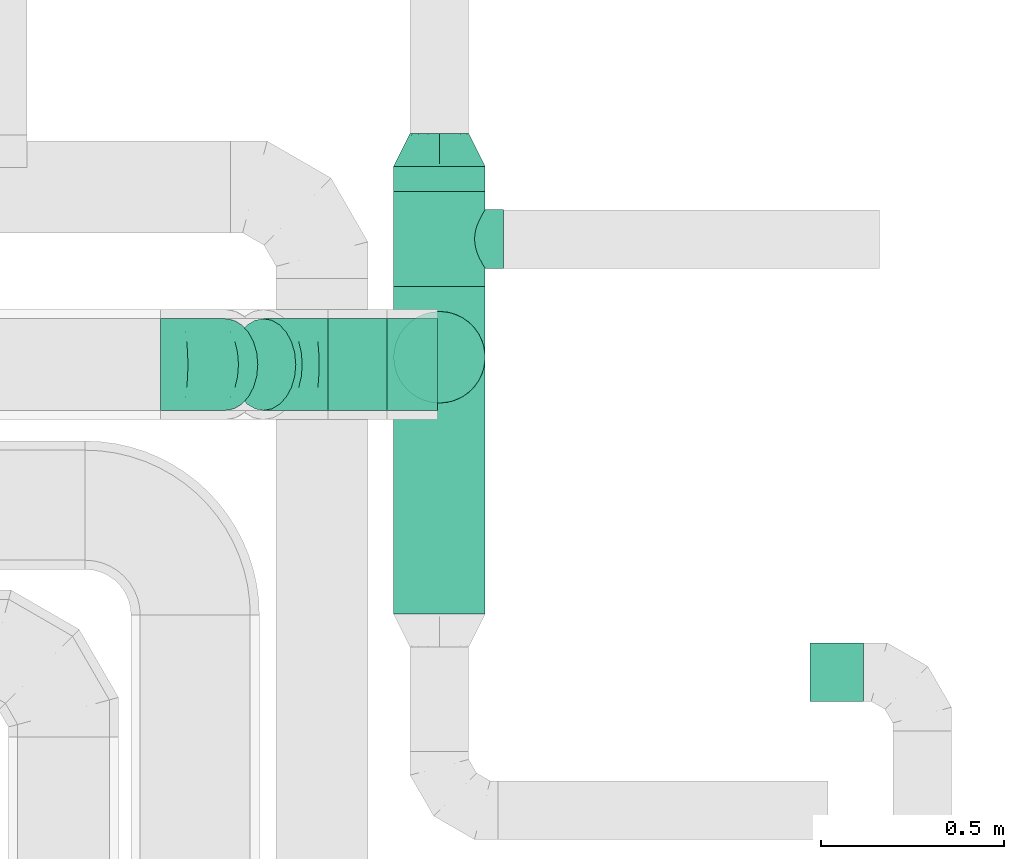
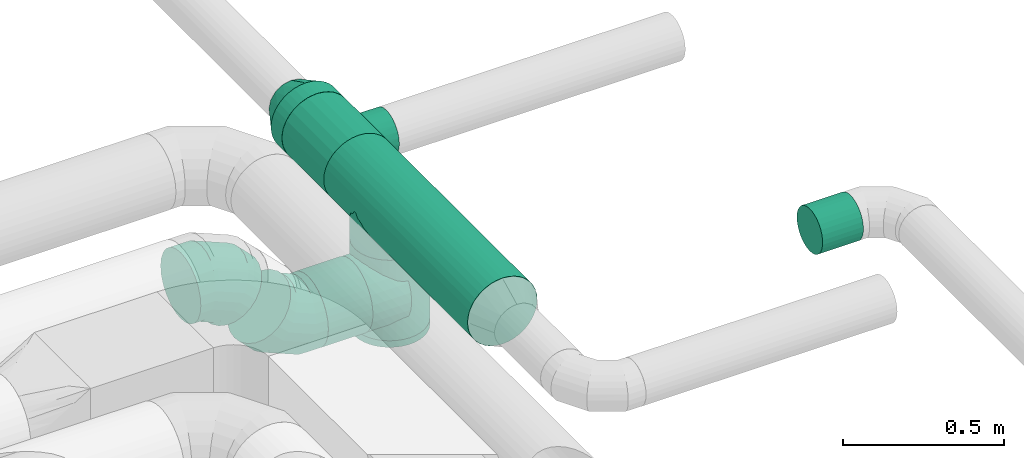
# One storey, part 74 of 92: 7 flow fittings, 5 flow segments.
"""IFC2X3 building model written with IfcOpenShell, lengths in millimetres."""

from ifc_helpers import new_model, entity, si_unit, converted_unit, derived_unit, direction, frame, origin, origin_2d_with_axis, place, context, subcontext, project, spatial, circle, extrude, faceted_brep, source, transform, mapped, material, type_object, type_shapes, element, save


model = new_model("IFC2X3")

# Units and contexts
model_context = context("Model", 3, precision=0.01, world=origin(), true_north=direction((6.12303176911189e-17, 1.0)))
body_context = subcontext(model_context, "Body", "Model", "MODEL_VIEW")
ifc_project = project(units=[si_unit("LENGTHUNIT", "METRE", prefix="MILLI"), si_unit("AREAUNIT", "SQUARE_METRE"), si_unit("VOLUMEUNIT", "CUBIC_METRE"), converted_unit("PLANEANGLEUNIT", "DEGREE", entity("IfcRatioMeasure", 0.0174532925199433), si_unit("PLANEANGLEUNIT", "RADIAN"), dimensions=[0, 0, 0, 0, 0, 0, 0]), si_unit("MASSUNIT", "GRAM", prefix="KILO"), derived_unit("MASSDENSITYUNIT", [(si_unit("MASSUNIT", "GRAM", prefix="KILO"), 1), (si_unit("LENGTHUNIT", "METRE"), -3)]), derived_unit("MOMENTOFINERTIAUNIT", [(si_unit("LENGTHUNIT", "METRE"), 4)]), si_unit("TIMEUNIT", "SECOND"), si_unit("FREQUENCYUNIT", "HERTZ"), si_unit("THERMODYNAMICTEMPERATUREUNIT", "DEGREE_CELSIUS"), derived_unit("THERMALTRANSMITTANCEUNIT", [(si_unit("MASSUNIT", "GRAM", prefix="KILO"), 1), (si_unit("THERMODYNAMICTEMPERATUREUNIT", "KELVIN"), -1), (si_unit("TIMEUNIT", "SECOND"), -3)]), derived_unit("VOLUMETRICFLOWRATEUNIT", [(si_unit("LENGTHUNIT", "METRE"), 3), (si_unit("TIMEUNIT", "SECOND"), -1)]), derived_unit("MASSFLOWRATEUNIT", [(si_unit("MASSUNIT", "GRAM", prefix="KILO"), 1), (si_unit("TIMEUNIT", "SECOND"), -1)]), derived_unit("ROTATIONALFREQUENCYUNIT", [(si_unit("TIMEUNIT", "SECOND"), -1)]), si_unit("ELECTRICCURRENTUNIT", "AMPERE"), si_unit("ELECTRICVOLTAGEUNIT", "VOLT"), si_unit("POWERUNIT", "WATT"), si_unit("FORCEUNIT", "NEWTON", prefix="KILO"), si_unit("ILLUMINANCEUNIT", "LUX"), si_unit("LUMINOUSFLUXUNIT", "LUMEN"), si_unit("LUMINOUSINTENSITYUNIT", "CANDELA"), derived_unit("USERDEFINED", [(si_unit("MASSUNIT", "GRAM", prefix="KILO"), -1), (si_unit("LENGTHUNIT", "METRE"), -2), (si_unit("TIMEUNIT", "SECOND"), 3), (si_unit("LUMINOUSFLUXUNIT", "LUMEN"), 1)]), derived_unit("LINEARVELOCITYUNIT", [(si_unit("LENGTHUNIT", "METRE"), 1), (si_unit("TIMEUNIT", "SECOND"), -1)]), si_unit("PRESSUREUNIT", "PASCAL"), derived_unit("USERDEFINED", [(si_unit("LENGTHUNIT", "METRE"), -2), (si_unit("MASSUNIT", "GRAM", prefix="KILO"), 1), (si_unit("TIMEUNIT", "SECOND"), -2)]), derived_unit("LINEARFORCEUNIT", [(si_unit("MASSUNIT", "GRAM", prefix="KILO"), 1), (si_unit("LENGTHUNIT", "METRE"), 1), (si_unit("TIMEUNIT", "SECOND"), -2), (si_unit("LENGTHUNIT", "METRE"), -1)]), derived_unit("PLANARFORCEUNIT", [(si_unit("MASSUNIT", "GRAM", prefix="KILO"), 1), (si_unit("LENGTHUNIT", "METRE"), 1), (si_unit("TIMEUNIT", "SECOND"), -2), (si_unit("LENGTHUNIT", "METRE"), -2)])], contexts=[model_context])

# Site, building, storey
site_placement = place(None, origin())
site = spatial("IfcSite", under=ifc_project, at=site_placement, CompositionType="ELEMENT")
building_placement = place(site_placement, origin())
building = spatial("IfcBuilding", under=site, at=building_placement, CompositionType="ELEMENT")
storey_placement = place(building_placement, frame((0.0, 0.0, 4200.0)))
storey = spatial("IfcBuildingStorey", under=building, at=storey_placement, CompositionType="ELEMENT", Elevation=4200.0)

# Flow segments
duct_segment_type = type_object("IfcDuctSegmentType", PredefinedType="NOTDEFINED")
flow_segment_1_placement = place(storey_placement, frame((63120.09, 14801.78, 3268.4)))
element("IfcFlowSegment", 1, at=flow_segment_1_placement, inside=storey, type_object=duct_segment_type, context=body_context, shape_type="SweptSolid", body=[
    extrude(circle(Radius=80.0, at=origin_2d_with_axis()), frame((0.0, 81.6, 81.6), z_axis=(1.0, 0.0, 0.0), x_axis=(0.0, 1.0, 0.0)), (0.0, 0.0, 1.0), 146.331439886492),
])
flow_segment_2_placement = place(storey_placement, frame((61806.89, 15595.41, 2873.4)))
element("IfcFlowSegment", 2, at=flow_segment_2_placement, inside=storey, type_object=duct_segment_type, context=body_context, shape_type="SweptSolid", body=[
    extrude(circle(Radius=125.0, at=origin_2d_with_axis()), frame((0.0, 126.6, 126.6), z_axis=(1.0, 0.0, 0.0), x_axis=(0.0, 1.0, 0.0)), (0.0, 0.0, 1.0), 159.717263995072),
])
flow_segment_3_placement = place(storey_placement, frame((61983.4, 15615.38, 2850.0)))
element("IfcFlowSegment", 3, at=flow_segment_3_placement, inside=storey, type_object=duct_segment_type, context=body_context, shape_type="SweptSolid", body=[
    extrude(circle(Radius=125.0, at=origin_2d_with_axis()), frame((126.6, 126.6, 0.0), z_axis=(0.0, 0.0, 1.0), x_axis=(0.0, -1.0, 0.0)), (0.0, 0.0, 1.0), 305.000000000008),
])
flow_segment_4_placement = place(storey_placement, frame((61983.4, 16194.33, 3173.4)))
element("IfcFlowSegment", 4, at=flow_segment_4_placement, inside=storey, type_object=duct_segment_type, context=body_context, shape_type="SweptSolid", body=[
    extrude(circle(Radius=125.0, at=origin_2d_with_axis()), frame((126.6, 0.0, 126.6), z_axis=(0.0, 1.0, 0.0), x_axis=(1.0, 0.0, 0.0)), (0.0, 0.0, 1.0), 67.6437884777552),
])
flow_segment_5_placement = place(storey_placement, frame((61983.4, 15041.98, 3173.4)))
element("IfcFlowSegment", 5, at=flow_segment_5_placement, inside=storey, type_object=duct_segment_type, context=body_context, shape_type="SweptSolid", body=[
    extrude(circle(Radius=125.0, at=origin_2d_with_axis()), frame((126.6, 0.0, 126.6), z_axis=(0.0, 1.0, 0.0), x_axis=(1.0, 0.0, 0.0)), (0.0, 0.0, 1.0), 892.356211522237),
])

# Flow fittings
ifc_material = material()
duct_fitting_type_1 = type_object("IfcDuctFittingType", PredefinedType="NOTDEFINED", material=ifc_material)
shared_shape_1 = source(origin(), body_context, "Body", "SweptSolid", [
    extrude(circle(Radius=124.999999999999, at=origin_2d_with_axis()), frame((0.0, 0.0, 0.0), z_axis=(1.0, 0.0, 0.0), x_axis=(0.0, 1.0, 0.0)), (0.0, 0.0, 1.0), 25.0000000000018),
])
type_shapes(duct_fitting_type_1, [shared_shape_1])
flow_fitting_1_placement = place(storey_placement, frame((62110.0, 15741.98, 2850.0), z_axis=(-1.0, 0.0, 0.0), x_axis=(0.0, 0.0, -1.0)))
element("IfcFlowFitting", 6, at=flow_fitting_1_placement, inside=storey, type_object=duct_fitting_type_1, material=ifc_material, context=body_context, shape_type="MappedRepresentation", body=[
    mapped(shared_shape_1, transform((0.0, 0.0, 0.0), scale=1.0)),
])
duct_fitting_type_2 = type_object("IfcDuctFittingType", PredefinedType="NOTDEFINED", material=ifc_material)
shared_shape_2 = source(origin(), body_context, "Body", "Brep", [
    faceted_brep([(20.0, 0.0, -125.0), (20.0, 32.35, -120.74), (20.0, 62.5, -108.25), (20.0, 88.39, -88.39), (20.0, 108.25, -62.5), (20.0, 120.74, -32.35), (20.0, 125.0, 0.0), (20.0, 120.74, 32.35), (20.0, 108.25, 62.5), (20.0, 88.39, 88.39), (20.0, 62.5, 108.25), (20.0, 32.35, 120.74), (20.0, 0.0, 125.0), (20.0, -32.35, 120.74), (20.0, -62.5, 108.25), (20.0, -88.39, 88.39), (20.0, -108.25, 62.5), (20.0, -120.74, 32.35), (20.0, -125.0, 0.0), (20.0, -120.74, -32.35), (20.0, -108.25, -62.5), (20.0, -88.39, -88.39), (20.0, -62.5, -108.25), (20.0, -32.35, -120.74), (0.0, 0.0, 125.0), (-118.9, 0.0, 125.0), (-118.9, -32.35, 120.74), (0.0, -32.35, 120.74), (-118.9, -62.5, 108.25), (0.0, -62.5, 108.25), (0.0, -88.39, 88.39), (-118.9, -88.39, 88.39), (0.0, -108.25, 62.5), (-118.9, -108.25, 62.5), (-118.9, -120.74, 32.35), (0.0, -120.74, 32.35), (-118.9, -125.0, 0.0), (0.0, -125.0, 0.0), (-118.9, -120.74, -32.35), (0.0, -120.74, -32.35), (-118.9, -108.25, -62.5), (0.0, -108.25, -62.5), (0.0, -88.39, -88.39), (-118.9, -88.39, -88.39), (0.0, -62.5, -108.25), (-118.9, -62.5, -108.25), (-118.9, -32.35, -120.74), (0.0, -32.35, -120.74), (-118.9, 0.0, -125.0), (0.0, 0.0, -125.0), (-118.9, 32.35, -120.74), (0.0, 32.35, -120.74), (-118.9, 62.5, -108.25), (0.0, 62.5, -108.25), (0.0, 88.39, -88.39), (-118.9, 88.39, -88.39), (0.0, 108.25, -62.5), (-118.9, 108.25, -62.5), (-118.9, 120.74, -32.35), (0.0, 120.74, -32.35), (-118.9, 125.0, 0.0), (0.0, 125.0, 0.0), (-118.9, 120.74, 32.35), (0.0, 120.74, 32.35), (-118.9, 108.25, 62.5), (0.0, 108.25, 62.5), (0.0, 88.39, 88.39), (-118.9, 88.39, 88.39), (0.0, 62.5, 108.25), (-118.9, 62.5, 108.25), (-118.9, 32.35, 120.74), (0.0, 32.35, 120.74)], [[[0, 1, 2, 3, 4, 5, 6, 7, 8, 9, 10, 11, 12, 13, 14, 15, 16, 17, 18, 19, 20, 21, 22, 23]], [[13, 12, 24, 25, 26, 27]], [[14, 13, 27, 26, 28, 29]], [[30, 15, 14, 29, 28, 31]], [[17, 16, 32, 33, 34, 35]], [[18, 17, 35, 34, 36, 37]], [[32, 16, 15, 30, 31, 33]], [[19, 18, 37, 36, 38, 39]], [[20, 19, 39, 38, 40, 41]], [[42, 21, 20, 41, 40, 43]], [[23, 22, 44, 45, 46, 47]], [[0, 23, 47, 46, 48, 49]], [[44, 22, 21, 42, 43, 45]], [[1, 0, 49, 48, 50, 51]], [[2, 1, 51, 50, 52, 53]], [[54, 3, 2, 53, 52, 55]], [[5, 4, 56, 57, 58, 59]], [[6, 5, 59, 58, 60, 61]], [[56, 4, 3, 54, 55, 57]], [[7, 6, 61, 60, 62, 63]], [[8, 7, 63, 62, 64, 65]], [[66, 9, 8, 65, 64, 67]], [[11, 10, 68, 69, 70, 71]], [[12, 11, 71, 70, 25, 24]], [[68, 10, 9, 66, 67, 69]], [[46, 45, 43, 40, 38, 36, 34, 33, 31, 28, 26, 25, 70, 69, 67, 64, 62, 60, 58, 57, 55, 52, 50, 48]]]),
])
type_shapes(duct_fitting_type_2, [shared_shape_2])
flow_fitting_2_placement = place(storey_placement, frame((61986.61, 15722.0, 3000.0), z_axis=(0.0, 1.0, 0.0), x_axis=(-1.0, 0.0, 0.0)))
element("IfcFlowFitting", 7, at=flow_fitting_2_placement, inside=storey, type_object=duct_fitting_type_2, material=ifc_material, context=body_context, shape_type="MappedRepresentation", body=[
    mapped(shared_shape_2, transform((0.0, 0.0, 0.0), scale=1.0)),
])
duct_fitting_type_3 = type_object("IfcDuctFittingType", PredefinedType="NOTDEFINED", material=ifc_material)
shared_shape_3 = source(origin(), body_context, "Body", "Brep", [
    faceted_brep([(20.0, 32.35, -120.74), (20.0, 62.5, -108.25), (20.0, 88.39, -88.39), (20.0, 108.25, -62.5), (20.0, 120.74, -32.35), (20.0, 125.0, 0.0), (20.0, 120.74, 32.35), (20.0, 108.25, 62.5), (20.0, 88.39, 88.39), (20.0, 62.5, 108.25), (20.0, 32.35, 120.74), (20.0, 0.0, 125.0), (20.0, -32.35, 120.74), (20.0, -62.5, 108.25), (20.0, -88.39, 88.39), (20.0, -108.25, 62.5), (20.0, -120.74, 32.35), (20.0, -125.0, 0.0), (20.0, -120.74, -32.35), (20.0, -108.25, -62.5), (20.0, -88.39, -88.39), (20.0, -62.5, -108.25), (20.0, -32.35, -120.74), (20.0, 0.0, -125.0), (0.0, 0.0, 125.0), (0.0, 32.35, 120.74), (-118.9, 32.35, 120.74), (-118.9, 0.0, 125.0), (0.0, 62.5, 108.25), (-118.9, 62.5, 108.25), (0.0, 88.39, 88.39), (-118.9, 88.39, 88.39), (0.0, 108.25, 62.5), (0.0, 120.74, 32.35), (-118.9, 120.74, 32.35), (-118.9, 108.25, 62.5), (0.0, 125.0, 0.0), (-118.9, 125.0, 0.0), (0.0, 120.74, -32.35), (-118.9, 120.74, -32.35), (0.0, 108.25, -62.5), (-118.9, 108.25, -62.5), (0.0, 88.39, -88.39), (-118.9, 88.39, -88.39), (0.0, 62.5, -108.25), (0.0, 32.35, -120.74), (-118.9, 32.35, -120.74), (-118.9, 62.5, -108.25), (0.0, 0.0, -125.0), (-118.9, 0.0, -125.0), (0.0, -32.35, -120.74), (-118.9, -32.35, -120.74), (0.0, -62.5, -108.25), (-118.9, -62.5, -108.25), (0.0, -88.39, -88.39), (-118.9, -88.39, -88.39), (0.0, -108.25, -62.5), (0.0, -120.74, -32.35), (-118.9, -120.74, -32.35), (-118.9, -108.25, -62.5), (0.0, -125.0, 0.0), (-118.9, -125.0, 0.0), (0.0, -120.74, 32.35), (-118.9, -120.74, 32.35), (0.0, -108.25, 62.5), (-118.9, -108.25, 62.5), (0.0, -88.39, 88.39), (-118.9, -88.39, 88.39), (0.0, -62.5, 108.25), (0.0, -32.35, 120.74), (-118.9, -32.35, 120.74), (-118.9, -62.5, 108.25)], [[[0, 1, 2, 3, 4, 5, 6, 7, 8, 9, 10, 11, 12, 13, 14, 15, 16, 17, 18, 19, 20, 21, 22, 23]], [[24, 11, 10, 25, 26, 27]], [[25, 10, 9, 28, 29, 26]], [[28, 9, 8, 30, 31, 29]], [[32, 7, 6, 33, 34, 35]], [[33, 6, 5, 36, 37, 34]], [[30, 8, 7, 32, 35, 31]], [[36, 5, 4, 38, 39, 37]], [[38, 4, 3, 40, 41, 39]], [[40, 3, 2, 42, 43, 41]], [[44, 1, 0, 45, 46, 47]], [[45, 0, 23, 48, 49, 46]], [[42, 2, 1, 44, 47, 43]], [[48, 23, 22, 50, 51, 49]], [[50, 22, 21, 52, 53, 51]], [[52, 21, 20, 54, 55, 53]], [[56, 19, 18, 57, 58, 59]], [[57, 18, 17, 60, 61, 58]], [[54, 20, 19, 56, 59, 55]], [[60, 17, 16, 62, 63, 61]], [[62, 16, 15, 64, 65, 63]], [[64, 15, 14, 66, 67, 65]], [[68, 13, 12, 69, 70, 71]], [[69, 12, 11, 24, 27, 70]], [[66, 14, 13, 68, 71, 67]], [[49, 51, 53, 55, 59, 58, 61, 63, 65, 67, 71, 70, 27, 26, 29, 31, 35, 34, 37, 39, 41, 43, 47, 46]]]),
])
type_shapes(duct_fitting_type_3, [shared_shape_3])
flow_fitting_3_placement = place(storey_placement, frame((62110.0, 15741.98, 3175.0), z_axis=(-1.0, 0.0, 0.0), x_axis=(0.0, 0.0, -1.0)))
element("IfcFlowFitting", 8, at=flow_fitting_3_placement, inside=storey, type_object=duct_fitting_type_3, material=ifc_material, context=body_context, shape_type="MappedRepresentation", body=[
    mapped(shared_shape_3, transform((0.0, 0.0, 0.0), scale=1.0)),
])
duct_fitting_type_4 = type_object("IfcDuctFittingType", PredefinedType="NOTDEFINED", material=ifc_material)
shared_shape_4 = source(origin(), body_context, "Body", "Brep", [
    faceted_brep([(20.71, -175.0, -77.27), (40.0, -175.0, -69.28), (56.57, -175.0, -56.57), (69.28, -175.0, -40.0), (77.27, -175.0, -20.71), (80.0, -175.0, 0.0), (77.27, -175.0, 20.71), (69.28, -175.0, 40.0), (56.57, -175.0, 56.57), (40.0, -175.0, 69.28), (20.71, -175.0, 77.27), (0.0, -175.0, 80.0), (-20.71, -175.0, 77.27), (-40.0, -175.0, 69.28), (-56.57, -175.0, 56.57), (-69.28, -175.0, 40.0), (-77.27, -175.0, 20.71), (-80.0, -175.0, 0.0), (-77.27, -175.0, -20.71), (-69.28, -175.0, -40.0), (-56.57, -175.0, -56.57), (-40.0, -175.0, -69.28), (-20.71, -175.0, -77.27), (0.0, -175.0, -80.0), (14.28, -97.1, 78.71), (27.87, -100.01, 74.99), (51.42, -108.95, 61.28), (40.32, -104.17, 69.09), (0.0, -96.05, 80.0), (61.03, -113.8, 51.72), (74.95, -121.83, 27.98), (78.71, -124.18, 14.29), (68.96, -118.24, 40.56), (80.0, -125.0, 0.0), (78.71, -124.18, -14.31), (74.94, -121.83, -27.99), (61.02, -113.79, -51.73), (68.95, -118.23, -40.57), (51.42, -108.94, -61.29), (27.87, -100.01, -74.99), (14.28, -97.1, -78.72), (40.32, -104.17, -69.1), (0.0, -96.05, -80.0), (-14.28, -97.1, -78.71), (-27.87, -100.01, -74.99), (-51.42, -108.95, -61.28), (-40.32, -104.17, -69.09), (-61.03, -113.8, -51.72), (-74.95, -121.83, -27.98), (-78.71, -124.18, -14.29), (-68.96, -118.24, -40.56), (-80.0, -125.0, 0.0), (-78.71, -124.18, 14.29), (-74.95, -121.83, 27.98), (-61.03, -113.8, 51.72), (-68.96, -118.24, 40.56), (-51.42, -108.95, 61.28), (-27.87, -100.01, 74.99), (-14.28, -97.1, 78.71), (-40.32, -104.17, 69.09), (-130.0, 0.0, -125.0), (-130.0, -32.35, -120.74), (-130.0, -62.5, -108.25), (-130.0, -88.39, -88.39), (-130.0, -108.25, -62.5), (-130.0, -114.5, -47.43), (-130.0, -120.74, -32.35), (-130.0, -122.87, -16.18), (-130.0, -125.0, 0.0), (-130.0, -122.87, 16.18), (-130.0, -120.74, 32.35), (-130.0, -114.5, 47.43), (-130.0, -108.25, 62.5), (-130.0, -88.39, 88.39), (-130.0, -62.5, 108.25), (-130.0, -32.35, 120.74), (-130.0, 0.0, 125.0), (-130.0, 32.35, 120.74), (-130.0, 62.5, 108.25), (-130.0, 88.39, 88.39), (-130.0, 108.25, 62.5), (-130.0, 120.74, 32.35), (-130.0, 125.0, 0.0), (-130.0, 120.74, -32.35), (-130.0, 108.25, -62.5), (-130.0, 88.39, -88.39), (-130.0, 62.5, -108.25), (-130.0, 32.35, -120.74), (130.0, 32.35, -120.74), (130.0, 62.5, -108.25), (130.0, 88.39, -88.39), (130.0, 108.25, -62.5), (130.0, 120.74, -32.35), (130.0, 125.0, 0.0), (130.0, 120.74, 32.35), (130.0, 108.25, 62.5), (130.0, 88.39, 88.39), (130.0, 62.5, 108.25), (130.0, 32.35, 120.74), (130.0, 0.0, 125.0), (130.0, -32.35, 120.74), (130.0, -62.5, 108.25), (130.0, -88.39, 88.39), (130.0, -108.25, 62.5), (130.0, -114.5, 47.43), (130.0, -120.74, 32.35), (130.0, -122.87, 16.18), (130.0, -125.0, 0.0), (130.0, -122.87, -16.18), (130.0, -120.74, -32.35), (130.0, -114.5, -47.43), (130.0, -108.25, -62.5), (130.0, -88.39, -88.39), (130.0, -62.5, -108.25), (130.0, -32.35, -120.74), (130.0, 0.0, -125.0)], [[[0, 1, 2, 3, 4, 5, 6, 7, 8, 9, 10, 11, 12, 13, 14, 15, 16, 17, 18, 19, 20, 21, 22, 23]], [[24, 11, 10]], [[10, 9, 25]], [[26, 9, 8]], [[26, 27, 9]], [[28, 11, 24]], [[24, 10, 25]], [[9, 27, 25]], [[29, 8, 7]], [[30, 7, 6]], [[31, 6, 5]], [[32, 29, 7]], [[31, 30, 6]], [[33, 31, 5]], [[32, 7, 30]], [[8, 29, 26]], [[34, 33, 5]], [[34, 5, 4]], [[35, 4, 3]], [[35, 34, 4]], [[36, 37, 3]], [[35, 3, 37]], [[3, 2, 36]], [[38, 2, 1]], [[1, 0, 39]], [[23, 40, 0]], [[38, 1, 41]], [[0, 40, 39]], [[39, 41, 1]], [[40, 23, 42]], [[2, 38, 36]], [[43, 23, 22]], [[22, 21, 44]], [[45, 21, 20]], [[45, 46, 21]], [[42, 23, 43]], [[43, 22, 44]], [[21, 46, 44]], [[47, 20, 19]], [[48, 19, 18]], [[49, 18, 17]], [[50, 47, 19]], [[49, 48, 18]], [[51, 49, 17]], [[50, 19, 48]], [[20, 47, 45]], [[52, 51, 17]], [[52, 17, 16]], [[53, 16, 15]], [[53, 52, 16]], [[54, 55, 15]], [[53, 15, 55]], [[15, 14, 54]], [[56, 14, 13]], [[57, 13, 12]], [[58, 12, 11]], [[56, 13, 59]], [[12, 58, 57]], [[57, 59, 13]], [[58, 11, 28]], [[14, 56, 54]], [[60, 61, 62, 63, 64, 65, 66, 67, 68, 69, 70, 71, 72, 73, 74, 75, 76, 77, 78, 79, 80, 81, 82, 83, 84, 85, 86, 87]], [[88, 89, 90, 91, 92, 93, 94, 95, 96, 97, 98, 99, 100, 101, 102, 103, 104, 105, 106, 107, 108, 109, 110, 111, 112, 113, 114, 115]], [[77, 76, 99, 98]], [[78, 77, 98, 97]], [[97, 96, 79, 78]], [[81, 80, 95, 94]], [[82, 81, 94, 93]], [[96, 95, 80, 79]], [[83, 82, 93, 92]], [[84, 83, 92, 91]], [[91, 90, 85, 84]], [[87, 86, 89, 88]], [[60, 87, 88, 115]], [[90, 89, 86, 85]], [[113, 62, 61, 114]], [[114, 61, 60, 115]], [[63, 62, 113, 112]], [[50, 65, 47]], [[111, 41, 39]], [[49, 68, 67]], [[40, 42, 112]], [[35, 108, 34]], [[39, 40, 112]], [[39, 112, 111]], [[112, 42, 63]], [[44, 64, 63]], [[36, 110, 37]], [[46, 64, 44]], [[45, 64, 46]], [[44, 63, 43]], [[63, 42, 43]], [[110, 109, 37]], [[36, 111, 110]], [[109, 35, 37]], [[111, 36, 38]], [[107, 33, 34]], [[109, 108, 35]], [[34, 108, 107]], [[50, 66, 65]], [[47, 65, 64]], [[49, 67, 48]], [[67, 66, 48]], [[68, 49, 51]], [[48, 66, 50]], [[47, 64, 45]], [[38, 41, 111]], [[33, 107, 31]], [[68, 51, 52]], [[30, 31, 106]], [[106, 105, 30]], [[105, 32, 30]], [[105, 104, 32]], [[103, 26, 29]], [[29, 104, 103]], [[68, 52, 69]], [[53, 70, 69]], [[55, 71, 70]], [[55, 54, 71]], [[55, 70, 53]], [[54, 56, 72]], [[27, 103, 25]], [[32, 104, 29]], [[102, 24, 25]], [[25, 103, 102]], [[53, 69, 52]], [[101, 100, 75, 74]], [[74, 73, 102, 101]], [[24, 102, 28]], [[76, 75, 100, 99]], [[72, 57, 73]], [[31, 107, 106]], [[72, 59, 57]], [[72, 56, 59]], [[57, 58, 73]], [[28, 73, 58]], [[28, 102, 73]], [[54, 72, 71]], [[26, 103, 27]]]),
])
type_shapes(duct_fitting_type_4, [shared_shape_4])
flow_fitting_4_placement = place(storey_placement, frame((62110.0, 16064.33, 3300.0), z_axis=(0.0, 0.0, 1.0), x_axis=(0.0, 1.0, 0.0)))
element("IfcFlowFitting", 9, at=flow_fitting_4_placement, inside=storey, type_object=duct_fitting_type_4, material=ifc_material, context=body_context, shape_type="MappedRepresentation", body=[
    mapped(shared_shape_4, transform((0.0, 0.0, 0.0), scale=1.0)),
])
duct_fitting_type_5 = type_object("IfcDuctFittingType", PredefinedType="NOTDEFINED", material=ifc_material)
shared_shape_5 = source(origin(), body_context, "Body", "Brep", [
    faceted_brep([(90.0, -73.47, -101.13), (90.0, -38.63, -118.88), (90.0, 0.0, -125.0), (90.0, 38.63, -118.88), (90.0, 73.47, -101.13), (90.0, 101.13, -73.47), (90.0, 118.88, -38.63), (90.0, 125.0, 0.0), (90.0, 118.88, 38.63), (90.0, 101.13, 73.47), (90.0, 73.47, 101.13), (90.0, 38.63, 118.88), (90.0, 0.0, 125.0), (90.0, -38.63, 118.88), (90.0, -73.47, 101.13), (90.0, -101.13, 73.47), (90.0, -118.88, 38.63), (90.0, -125.0, 0.0), (90.0, -118.88, -38.63), (90.0, -101.13, -73.47), (0.0, -30.61, -73.91), (0.0, -43.59, -65.24), (0.0, -56.57, -56.57), (0.0, -65.24, -43.59), (0.0, -73.91, -30.61), (0.0, -76.96, -15.31), (0.0, -80.0, 0.0), (0.0, -76.96, 15.31), (0.0, -73.91, 30.61), (0.0, -65.24, 43.59), (0.0, -56.57, 56.57), (0.0, -43.59, 65.24), (0.0, -30.61, 73.91), (0.0, -15.31, 76.96), (0.0, 0.0, 80.0), (0.0, 15.31, 76.96), (0.0, 30.61, 73.91), (0.0, 43.59, 65.24), (0.0, 56.57, 56.57), (0.0, 65.24, 43.59), (0.0, 73.91, 30.61), (0.0, 76.96, 15.31), (0.0, 80.0, 0.0), (0.0, 76.96, -15.31), (0.0, 73.91, -30.61), (0.0, 65.24, -43.59), (0.0, 56.57, -56.57), (0.0, 43.59, -65.24), (0.0, 30.61, -73.91), (0.0, 15.31, -76.96), (0.0, 0.0, -80.0), (0.0, -15.31, -76.96)], [[[0, 1, 2, 3, 4, 5, 6, 7, 8, 9, 10, 11, 12, 13, 14, 15, 16, 17, 18, 19]], [[20, 21, 22, 23, 24, 25, 26, 27, 28, 29, 30, 31, 32, 33, 34, 35, 36, 37, 38, 39, 40, 41, 42, 43, 44, 45, 46, 47, 48, 49, 50, 51]], [[7, 41, 8]], [[41, 40, 8]], [[40, 9, 8]], [[11, 36, 35]], [[41, 7, 42]], [[9, 40, 39, 38]], [[10, 38, 37, 36]], [[12, 35, 34]], [[11, 10, 36]], [[12, 11, 35]], [[38, 10, 9]], [[12, 33, 13]], [[33, 32, 13]], [[32, 14, 13]], [[16, 28, 27]], [[33, 12, 34]], [[14, 32, 31, 30]], [[15, 30, 29, 28]], [[17, 27, 26]], [[16, 15, 28]], [[17, 16, 27]], [[30, 15, 14]], [[17, 25, 18]], [[25, 24, 18]], [[24, 19, 18]], [[1, 20, 51]], [[25, 17, 26]], [[19, 24, 23, 22]], [[0, 22, 21, 20]], [[2, 51, 50]], [[1, 0, 20]], [[2, 1, 51]], [[22, 0, 19]], [[2, 49, 3]], [[49, 48, 3]], [[48, 4, 3]], [[6, 44, 43]], [[49, 2, 50]], [[4, 48, 47, 46]], [[5, 46, 45, 44]], [[7, 43, 42]], [[6, 5, 44]], [[7, 6, 43]], [[46, 5, 4]]]),
])
type_shapes(duct_fitting_type_5, [shared_shape_5])
flow_fitting_5_placement = place(storey_placement, frame((62110.0, 16351.98, 3300.0), z_axis=(0.0, 0.0, 1.0), x_axis=(0.0, -1.0, 0.0)))
element("IfcFlowFitting", 10, at=flow_fitting_5_placement, inside=storey, type_object=duct_fitting_type_5, material=ifc_material, context=body_context, shape_type="MappedRepresentation", body=[
    mapped(shared_shape_5, transform((0.0, 0.0, 0.0), scale=1.0)),
])
duct_fitting_type_6 = type_object("IfcDuctFittingType", PredefinedType="NOTDEFINED", material=ifc_material)
shared_shape_6 = source(origin(), body_context, "Body", "Brep", [
    faceted_brep([(-103.55, 0.0, -125.0), (-103.55, -32.35, -120.74), (-103.55, -62.5, -108.25), (-103.55, -88.39, -88.39), (-103.55, -108.25, -62.5), (-103.55, -120.74, -32.35), (-103.55, -125.0, 0.0), (-103.55, -120.74, 32.35), (-103.55, -108.25, 62.5), (-103.55, -88.39, 88.39), (-103.55, -62.5, 108.25), (-103.55, -32.35, 120.74), (-103.55, 0.0, 125.0), (-103.55, 32.35, 120.74), (-103.55, 62.5, 108.25), (-103.55, 88.39, 88.39), (-103.55, 108.25, 62.5), (-103.55, 120.74, 32.35), (-103.55, 125.0, 0.0), (-103.55, 120.74, -32.35), (-103.55, 108.25, -62.5), (-103.55, 88.39, -88.39), (-103.55, 62.5, -108.25), (-103.55, 32.35, -120.74), (-60.26, 32.35, 120.74), (-66.26, 62.5, 108.25), (-53.83, 0.0, 125.0), (-71.41, 88.39, 88.39), (-77.84, 120.74, 32.35), (-78.69, 125.0, 0.0), (-75.36, 108.25, 62.5), (-75.36, 108.25, -62.5), (-71.41, 88.39, -88.39), (-77.84, 120.74, -32.35), (-60.26, 32.35, -120.74), (-53.83, 0.0, -125.0), (-66.26, 62.5, -108.25), (-47.39, -32.35, -120.74), (-41.39, -62.5, -108.25), (-36.24, -88.39, -88.39), (-32.29, -108.25, -62.5), (-29.81, -120.74, -32.35), (-28.96, -125.0, 0.0), (-29.81, -120.74, 32.35), (-32.29, -108.25, 62.5), (-36.24, -88.39, 88.39), (-41.39, -62.5, 108.25), (-47.39, -32.35, 120.74), (19.73, 65.49, 120.74), (2.66, 91.05, 108.25), (38.06, 38.06, 125.0), (-12.01, 112.99, 88.39), (-23.26, 129.83, 62.5), (-30.33, 140.42, 32.35), (-32.75, 144.03, 0.0), (-30.33, 140.42, -32.35), (-23.26, 129.83, -62.5), (-12.01, 112.99, -88.39), (19.73, 65.49, -120.74), (38.06, 38.06, -125.0), (2.66, 91.05, -108.25), (56.39, 10.63, -120.74), (73.46, -14.92, -108.25), (88.13, -36.87, -88.39), (99.38, -53.71, -62.5), (106.45, -64.3, -32.35), (108.87, -67.91, 0.0), (106.45, -64.3, 32.35), (99.38, -53.71, 62.5), (88.13, -36.87, 88.39), (73.46, -14.92, 108.25), (56.39, 10.63, 120.74), (73.22, 73.22, 125.0), (50.35, 96.1, 120.74), (29.03, 117.42, 108.25), (10.72, 135.72, 88.39), (-3.32, 149.77, 62.5), (-12.15, 158.6, 32.35), (-15.17, 161.61, 0.0), (-12.15, 158.6, -32.35), (-3.32, 149.77, -62.5), (10.72, 135.72, -88.39), (29.03, 117.42, -108.25), (50.35, 96.1, -120.74), (73.22, 73.22, -125.0), (96.1, 50.35, -120.74), (117.42, 29.03, -108.25), (135.72, 10.72, -88.39), (149.77, -3.32, -62.5), (158.6, -12.15, -32.35), (161.61, -15.16, 0.0), (158.6, -12.15, 32.35), (149.77, -3.32, 62.5), (135.72, 10.72, 88.39), (117.42, 29.03, 108.25), (96.1, 50.35, 120.74)], [[[0, 1, 2, 3, 4, 5, 6, 7, 8, 9, 10, 11, 12, 13, 14, 15, 16, 17, 18, 19, 20, 21, 22, 23]], [[24, 25, 14, 13]], [[26, 24, 13, 12]], [[14, 25, 27, 15]], [[28, 29, 18, 17]], [[30, 28, 17, 16]], [[15, 27, 30, 16]], [[20, 31, 32, 21]], [[33, 31, 20, 19]], [[18, 29, 33, 19]], [[34, 35, 0, 23]], [[36, 34, 23, 22]], [[32, 36, 22, 21]], [[1, 0, 35, 37]], [[2, 1, 37, 38]], [[3, 2, 38, 39]], [[5, 4, 40, 41]], [[6, 5, 41, 42]], [[39, 40, 4, 3]], [[6, 42, 43, 7]], [[7, 43, 44, 8]], [[45, 9, 8, 44]], [[9, 45, 46, 10]], [[10, 46, 47, 11]], [[26, 12, 11, 47]], [[48, 49, 25, 24]], [[50, 48, 24, 26]], [[27, 25, 49, 51]], [[52, 53, 28, 30]], [[51, 52, 30, 27]], [[29, 28, 53, 54]], [[55, 56, 31, 33]], [[54, 55, 33, 29]], [[32, 31, 56, 57]], [[58, 59, 35, 34]], [[60, 58, 34, 36]], [[57, 60, 36, 32]], [[37, 35, 59, 61]], [[38, 37, 61, 62]], [[39, 38, 62, 63]], [[41, 40, 64, 65]], [[42, 41, 65, 66]], [[63, 64, 40, 39]], [[43, 42, 66, 67]], [[44, 43, 67, 68]], [[68, 69, 45, 44]], [[46, 45, 69, 70]], [[47, 46, 70, 71]], [[26, 47, 71, 50]], [[48, 50, 72, 73]], [[49, 48, 73, 74]], [[51, 49, 74, 75]], [[53, 52, 76, 77]], [[54, 53, 77, 78]], [[51, 75, 76, 52]], [[54, 78, 79, 55]], [[55, 79, 80, 56]], [[56, 80, 81, 57]], [[60, 82, 83, 58]], [[58, 83, 84, 59]], [[60, 57, 81, 82]], [[59, 84, 85, 61]], [[61, 85, 86, 62]], [[87, 63, 62, 86]], [[64, 88, 89, 65]], [[65, 89, 90, 66]], [[88, 64, 63, 87]], [[91, 92, 68, 67]], [[90, 91, 67, 66]], [[92, 93, 69, 68]], [[71, 70, 94, 95]], [[50, 71, 95, 72]], [[93, 94, 70, 69]], [[83, 82, 81, 80, 79, 78, 77, 76, 75, 74, 73, 72, 95, 94, 93, 92, 91, 90, 89, 88, 87, 86, 85, 84]]]),
])
type_shapes(duct_fitting_type_6, [shared_shape_6])
for number, where, z_axis, x_axis in (
    (11, (61703.34, 15722.0, 3000.0), (0.0, -1.0, 0.0), (0.707106445676223, 0.0, -0.707107116696712)),
    (12, (61453.34, 15722.0, 3250.0), (0.0, -1.0, 0.0), (-0.707106445676258, 0.0, 0.707107116696677)),
):
    element("IfcFlowFitting", number, at=place(storey_placement, frame(where, z_axis=z_axis, x_axis=x_axis)), inside=storey, type_object=duct_fitting_type_6, material=ifc_material, context=body_context, shape_type="MappedRepresentation", body=[
        mapped(shared_shape_6, transform((0.0, 0.0, 0.0), scale=1.0)),
    ])

save(model, "model.ifc")
